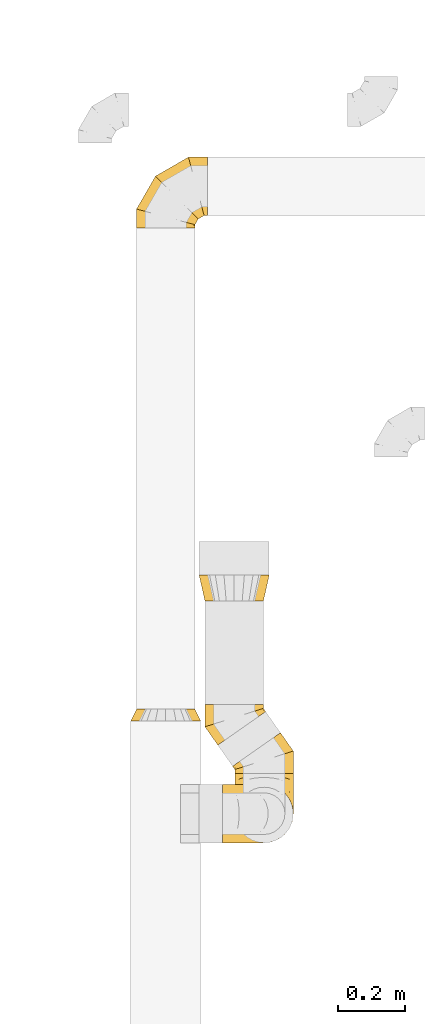
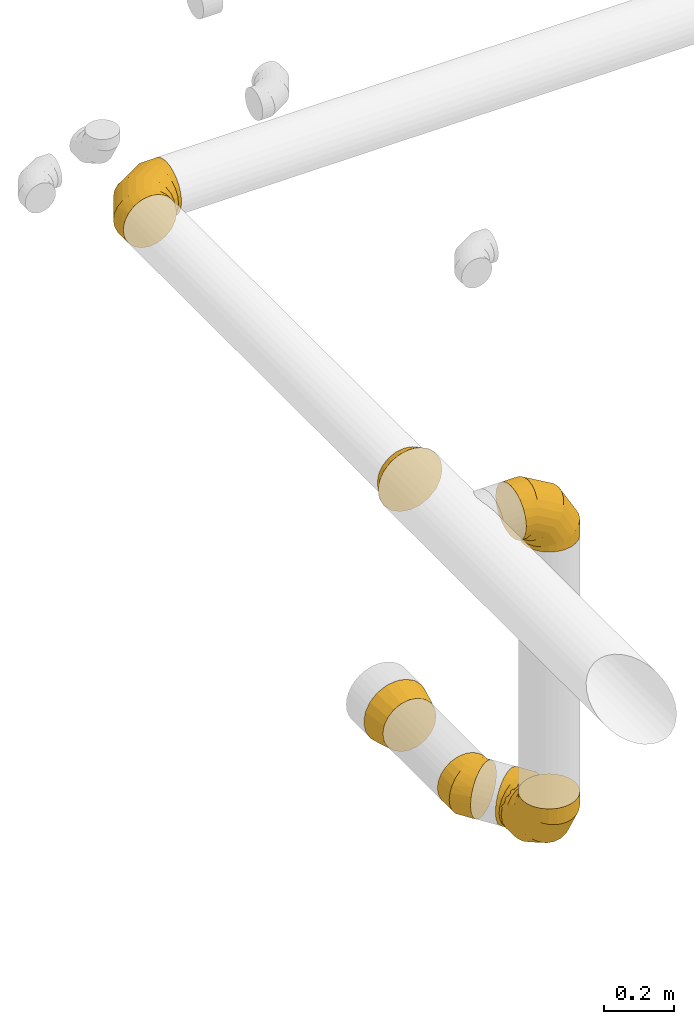
# One storey, part 27 of 97: 7 coverings.
"""IFC2X3 building model written with IfcOpenShell, lengths in millimetres."""

from ifc_helpers import new_model, entity, si_unit, converted_unit, derived_unit, direction, frame, origin, place, context, subcontext, project, spatial, faceted_brep, element, save


model = new_model("IFC2X3")

# Units and contexts
model_context = context("Model", 3, precision=0.01, world=origin(), true_north=direction((6.12303176911189e-17, 1.0)))
body_context = subcontext(model_context, "Body", "Model", "MODEL_VIEW")
ifc_project = project(units=[si_unit("LENGTHUNIT", "METRE", prefix="MILLI"), si_unit("AREAUNIT", "SQUARE_METRE"), si_unit("VOLUMEUNIT", "CUBIC_METRE"), converted_unit("PLANEANGLEUNIT", "DEGREE", entity("IfcRatioMeasure", 0.0174532925199433), si_unit("PLANEANGLEUNIT", "RADIAN"), dimensions=[0, 0, 0, 0, 0, 0, 0]), si_unit("MASSUNIT", "GRAM", prefix="KILO"), derived_unit("MASSDENSITYUNIT", [(si_unit("MASSUNIT", "GRAM", prefix="KILO"), 1), (si_unit("LENGTHUNIT", "METRE"), -3)]), derived_unit("MOMENTOFINERTIAUNIT", [(si_unit("LENGTHUNIT", "METRE"), 4)]), si_unit("TIMEUNIT", "SECOND"), si_unit("FREQUENCYUNIT", "HERTZ"), si_unit("THERMODYNAMICTEMPERATUREUNIT", "DEGREE_CELSIUS"), derived_unit("THERMALTRANSMITTANCEUNIT", [(si_unit("MASSUNIT", "GRAM", prefix="KILO"), 1), (si_unit("THERMODYNAMICTEMPERATUREUNIT", "KELVIN"), -1), (si_unit("TIMEUNIT", "SECOND"), -3)]), derived_unit("VOLUMETRICFLOWRATEUNIT", [(si_unit("LENGTHUNIT", "METRE"), 3), (si_unit("TIMEUNIT", "SECOND"), -1)]), derived_unit("MASSFLOWRATEUNIT", [(si_unit("MASSUNIT", "GRAM", prefix="KILO"), 1), (si_unit("TIMEUNIT", "SECOND"), -1)]), derived_unit("ROTATIONALFREQUENCYUNIT", [(si_unit("TIMEUNIT", "SECOND"), -1)]), si_unit("ELECTRICCURRENTUNIT", "AMPERE"), si_unit("ELECTRICVOLTAGEUNIT", "VOLT"), si_unit("POWERUNIT", "WATT"), si_unit("FORCEUNIT", "NEWTON", prefix="KILO"), si_unit("ILLUMINANCEUNIT", "LUX"), si_unit("LUMINOUSFLUXUNIT", "LUMEN"), si_unit("LUMINOUSINTENSITYUNIT", "CANDELA"), derived_unit("USERDEFINED", [(si_unit("MASSUNIT", "GRAM", prefix="KILO"), -1), (si_unit("LENGTHUNIT", "METRE"), -2), (si_unit("TIMEUNIT", "SECOND"), 3), (si_unit("LUMINOUSFLUXUNIT", "LUMEN"), 1)]), derived_unit("LINEARVELOCITYUNIT", [(si_unit("LENGTHUNIT", "METRE"), 1), (si_unit("TIMEUNIT", "SECOND"), -1)]), si_unit("PRESSUREUNIT", "PASCAL"), derived_unit("USERDEFINED", [(si_unit("LENGTHUNIT", "METRE"), -2), (si_unit("MASSUNIT", "GRAM", prefix="KILO"), 1), (si_unit("TIMEUNIT", "SECOND"), -2)]), derived_unit("LINEARFORCEUNIT", [(si_unit("MASSUNIT", "GRAM", prefix="KILO"), 1), (si_unit("LENGTHUNIT", "METRE"), 1), (si_unit("TIMEUNIT", "SECOND"), -2), (si_unit("LENGTHUNIT", "METRE"), -1)]), derived_unit("PLANARFORCEUNIT", [(si_unit("MASSUNIT", "GRAM", prefix="KILO"), 1), (si_unit("LENGTHUNIT", "METRE"), 1), (si_unit("TIMEUNIT", "SECOND"), -2), (si_unit("LENGTHUNIT", "METRE"), -2)])], contexts=[model_context])

# Site, building, storey
site_placement = place(None, origin())
site = spatial("IfcSite", under=ifc_project, at=site_placement, CompositionType="ELEMENT")
building_placement = place(site_placement, origin())
building = spatial("IfcBuilding", under=site, at=building_placement, CompositionType="ELEMENT")
storey_placement = place(building_placement, frame((0.0, 0.0, -4900.0)))
storey = spatial("IfcBuildingStorey", under=building, at=storey_placement, CompositionType="ELEMENT", Elevation=-4900.0)

# Coverings
covering_1_placement = place(storey_placement, frame((67387.61, 17132.04, 3893.4)))
element("IfcCovering", 1, at=covering_1_placement, inside=storey, PredefinedType="INSULATION", context=body_context, shape_type="Brep", body=[
    faceted_brep([(79.56, 35.0, 189.81), (106.6, 35.0, 194.1), (133.63, 35.0, 189.81), (158.03, 35.0, 177.38), (177.38, 35.0, 158.03), (189.81, 35.0, 133.63), (194.1, 35.0, 106.6), (189.81, 35.0, 79.56), (177.38, 35.0, 55.16), (158.03, 35.0, 35.81), (133.63, 35.0, 23.38), (106.6, 35.0, 19.1), (79.56, 35.0, 23.38), (55.16, 35.0, 35.81), (35.81, 35.0, 55.16), (23.38, 35.0, 79.56), (19.1, 35.0, 106.6), (23.38, 35.0, 133.63), (35.81, 35.0, 158.03), (55.16, 35.0, 177.38), (1.6, 0.0, 106.6), (6.73, 0.0, 74.15), (21.65, 0.0, 44.88), (44.88, 0.0, 21.65), (74.15, 0.0, 6.73), (106.6, 0.0, 1.6), (139.04, 0.0, 6.73), (168.31, 0.0, 21.65), (191.54, 0.0, 44.88), (206.46, 0.0, 74.15), (211.6, 0.0, 106.6), (206.46, 0.0, 139.04), (191.54, 0.0, 168.31), (168.31, 0.0, 191.54), (139.04, 0.0, 206.46), (106.6, 0.0, 211.6), (74.15, 0.0, 206.46), (44.88, 0.0, 191.54), (21.65, 0.0, 168.31), (6.73, 0.0, 139.04)], [[[0, 1, 2, 3, 4, 5, 6, 7, 8, 9, 10, 11, 12, 13, 14, 15, 16, 17, 18, 19]], [[20, 21, 22, 23, 24, 25, 26, 27, 28, 29, 30, 31, 32, 33, 34, 35, 36, 37, 38, 39]], [[26, 25, 11, 10]], [[26, 10, 9, 27]], [[9, 8, 28, 27]], [[7, 6, 30, 29]], [[8, 7, 29, 28]], [[21, 20, 16, 15]], [[21, 15, 14, 22]], [[14, 13, 23, 22]], [[12, 11, 25, 24]], [[13, 12, 24, 23]], [[36, 35, 1, 0]], [[36, 0, 19, 37]], [[19, 18, 38, 37]], [[17, 16, 20, 39]], [[18, 17, 39, 38]], [[31, 30, 6, 5]], [[31, 5, 4, 32]], [[4, 3, 33, 32]], [[2, 1, 35, 34]], [[3, 2, 34, 33]]]),
])
covering_2_placement = place(storey_placement, frame((67405.11, 18609.13, 3910.9)))
element("IfcCovering", 2, at=covering_2_placement, inside=storey, PredefinedType="INSULATION", context=body_context, shape_type="Brep", body=[
    faceted_brep([(116.13, 0.0, 172.31), (89.1, 0.0, 176.6), (62.06, 0.0, 172.31), (37.66, 0.0, 159.88), (18.31, 0.0, 140.53), (5.88, 0.0, 116.13), (1.6, 0.0, 89.1), (5.88, 0.0, 62.06), (18.31, 0.0, 37.66), (37.66, 0.0, 18.31), (62.06, 0.0, 5.88), (89.1, 0.0, 1.6), (116.13, 0.0, 5.88), (140.53, 0.0, 18.31), (159.88, 0.0, 37.66), (166.1, 0.0, 49.86), (172.31, 0.0, 62.06), (174.45, 0.0, 75.58), (176.6, 0.0, 89.1), (174.45, 0.0, 102.61), (172.31, 0.0, 116.13), (166.1, 0.0, 128.33), (159.88, 0.0, 140.53), (140.53, 0.0, 159.88), (214.1, 200.78, 45.35), (214.1, 209.52, 66.45), (214.1, 212.5, 89.1), (214.1, 209.52, 111.74), (214.1, 200.78, 132.85), (214.1, 186.87, 150.97), (214.1, 168.75, 164.87), (214.1, 147.65, 173.61), (214.1, 125.0, 176.6), (214.1, 102.35, 173.61), (214.1, 81.25, 164.87), (214.1, 63.13, 150.97), (214.1, 49.22, 132.85), (214.1, 40.48, 111.74), (214.1, 37.5, 89.1), (214.1, 40.48, 66.45), (214.1, 49.22, 45.35), (214.1, 63.13, 27.22), (214.1, 81.25, 13.32), (214.1, 102.35, 4.58), (214.1, 125.0, 1.6), (214.1, 147.65, 4.58), (214.1, 168.75, 13.32), (214.1, 186.87, 27.22), (157.16, 212.5, 89.1), (157.95, 209.52, 111.74), (160.3, 200.78, 132.85), (164.02, 186.87, 150.97), (168.88, 168.75, 164.87), (174.53, 147.65, 173.61), (180.6, 125.0, 176.6), (186.67, 102.35, 173.61), (192.32, 81.25, 164.87), (197.18, 63.13, 150.97), (200.91, 49.22, 132.85), (203.25, 40.48, 111.74), (204.05, 37.5, 89.1), (203.25, 40.48, 66.45), (200.91, 49.22, 45.35), (197.18, 63.13, 27.22), (186.67, 102.35, 4.58), (180.6, 125.0, 1.6), (192.32, 81.25, 13.32), (174.53, 147.65, 4.58), (168.88, 168.75, 13.32), (164.02, 186.87, 27.22), (160.3, 200.78, 45.35), (157.95, 209.52, 66.45), (58.53, 155.56, 89.1), (60.72, 153.38, 111.74), (67.12, 146.98, 132.85), (77.3, 136.8, 150.97), (90.56, 123.53, 164.87), (106.01, 108.08, 173.61), (122.59, 91.51, 176.6), (139.17, 74.93, 173.61), (154.62, 59.48, 164.87), (167.88, 46.21, 150.97), (178.06, 36.03, 132.85), (184.46, 29.63, 111.74), (186.64, 27.45, 89.1), (184.46, 29.63, 66.45), (178.06, 36.03, 45.35), (167.88, 46.21, 27.22), (139.17, 74.93, 4.58), (122.59, 91.51, 1.6), (154.62, 59.48, 13.32), (106.01, 108.08, 4.58), (90.56, 123.53, 13.32), (77.3, 136.8, 27.22), (67.12, 146.98, 45.35), (60.72, 153.38, 66.45), (1.6, 56.94, 89.1), (4.58, 56.14, 111.74), (13.32, 53.8, 132.85), (27.22, 50.07, 150.97), (45.35, 45.22, 164.87), (66.45, 39.56, 173.61), (89.1, 33.49, 176.6), (111.74, 27.43, 173.61), (132.85, 21.77, 164.87), (150.97, 16.92, 150.97), (164.87, 13.19, 132.85), (173.61, 10.85, 111.74), (175.1, 10.45, 100.42), (176.6, 10.05, 89.1), (173.61, 10.85, 66.45), (164.87, 13.19, 45.35), (175.1, 10.45, 77.77), (150.97, 16.92, 27.22), (111.74, 27.43, 4.58), (89.1, 33.49, 1.6), (132.85, 21.77, 13.32), (66.45, 39.56, 4.58), (45.35, 45.22, 13.32), (27.22, 50.07, 27.22), (13.32, 53.8, 45.35), (4.58, 56.14, 66.45)], [[[0, 1, 2, 3, 4, 5, 6, 7, 8, 9, 10, 11, 12, 13, 14, 15, 16, 17, 18, 19, 20, 21, 22, 23]], [[24, 25, 26, 27, 28, 29, 30, 31, 32, 33, 34, 35, 36, 37, 38, 39, 40, 41, 42, 43, 44, 45, 46, 47]], [[26, 48, 49, 27]], [[27, 49, 50, 28]], [[28, 50, 51, 29]], [[30, 52, 53, 31]], [[31, 53, 54, 32]], [[29, 51, 52, 30]], [[55, 56, 34, 33]], [[54, 55, 33, 32]], [[57, 35, 34, 56]], [[58, 59, 37, 36]], [[58, 36, 35, 57]], [[60, 38, 37, 59]], [[61, 62, 40, 39]], [[60, 61, 39, 38]], [[41, 40, 62, 63]], [[64, 65, 44, 43]], [[66, 64, 43, 42]], [[63, 66, 42, 41]], [[46, 45, 67, 68]], [[47, 46, 68, 69]], [[44, 65, 67, 45]], [[25, 24, 70, 71]], [[26, 25, 71, 48]], [[69, 70, 24, 47]], [[49, 48, 72, 73]], [[50, 49, 73, 74]], [[74, 75, 51, 50]], [[52, 51, 75, 76]], [[53, 52, 76, 77]], [[54, 53, 77, 78]], [[79, 80, 56, 55]], [[78, 79, 55, 54]], [[57, 56, 80, 81]], [[82, 83, 59, 58]], [[81, 82, 58, 57]], [[60, 59, 83, 84]], [[85, 86, 62, 61]], [[84, 85, 61, 60]], [[63, 62, 86, 87]], [[88, 89, 65, 64]], [[90, 88, 64, 66]], [[87, 90, 66, 63]], [[67, 65, 89, 91]], [[68, 67, 91, 92]], [[69, 68, 92, 93]], [[71, 70, 94, 95]], [[48, 71, 95, 72]], [[93, 94, 70, 69]], [[73, 72, 96, 97]], [[74, 73, 97, 98]], [[98, 99, 75, 74]], [[76, 75, 99, 100]], [[77, 76, 100, 101]], [[78, 77, 101, 102]], [[103, 104, 80, 79]], [[102, 103, 79, 78]], [[81, 80, 104, 105]], [[106, 107, 83, 82]], [[105, 106, 82, 81]], [[84, 83, 107, 108, 109]], [[110, 111, 86, 85]], [[85, 84, 109, 112, 110]], [[87, 86, 111, 113]], [[114, 115, 89, 88]], [[116, 114, 88, 90]], [[113, 116, 90, 87]], [[91, 89, 115, 117]], [[92, 91, 117, 118]], [[93, 92, 118, 119]], [[95, 94, 120, 121]], [[72, 95, 121, 96]], [[119, 120, 94, 93]], [[97, 6, 5]], [[98, 5, 4]], [[6, 97, 96]], [[97, 5, 98]], [[4, 99, 98]], [[100, 3, 2]], [[101, 2, 1]], [[99, 3, 100]], [[100, 2, 101]], [[1, 102, 101]], [[3, 99, 4]], [[103, 1, 0]], [[104, 0, 23]], [[103, 102, 1]], [[104, 103, 0]], [[23, 105, 104]], [[21, 20, 107]], [[18, 109, 108]], [[107, 20, 19]], [[106, 105, 22]], [[106, 22, 21]], [[107, 19, 108]], [[21, 107, 106]], [[18, 108, 19]], [[22, 105, 23]], [[110, 17, 16]], [[111, 15, 14]], [[18, 112, 109]], [[18, 17, 112]], [[110, 16, 15]], [[110, 15, 111]], [[14, 113, 111]], [[116, 13, 12]], [[114, 12, 11]], [[116, 113, 13]], [[115, 114, 11]], [[116, 12, 114]], [[17, 110, 112]], [[13, 113, 14]], [[117, 11, 10]], [[118, 10, 9]], [[11, 117, 115]], [[117, 10, 118]], [[9, 119, 118]], [[120, 8, 7]], [[121, 7, 6]], [[119, 8, 120]], [[121, 120, 7]], [[96, 121, 6]], [[8, 119, 9]]]),
])
covering_3_placement = place(storey_placement, frame((67699.89, 16764.8, 2770.9)))
element("IfcCovering", 3, at=covering_3_placement, inside=storey, PredefinedType="INSULATION", context=body_context, shape_type="Brep", body=[
    faceted_brep([(172.31, 214.1, 116.13), (176.6, 214.1, 89.1), (172.31, 214.1, 62.06), (159.88, 214.1, 37.66), (140.53, 214.1, 18.31), (116.13, 214.1, 5.88), (89.1, 214.1, 1.6), (62.06, 214.1, 5.88), (37.66, 214.1, 18.31), (18.31, 214.1, 37.66), (5.88, 214.1, 62.06), (1.6, 214.1, 89.1), (5.88, 214.1, 116.13), (18.31, 214.1, 140.53), (37.66, 214.1, 159.88), (49.86, 214.1, 166.1), (62.06, 214.1, 172.31), (75.58, 214.1, 174.45), (89.1, 214.1, 176.6), (102.61, 214.1, 174.45), (116.13, 214.1, 172.31), (128.33, 214.1, 166.1), (140.53, 214.1, 159.88), (159.88, 214.1, 140.53), (45.35, 13.32, 214.1), (66.45, 4.58, 214.1), (89.1, 1.6, 214.1), (111.74, 4.58, 214.1), (132.85, 13.32, 214.1), (150.97, 27.22, 214.1), (164.87, 45.35, 214.1), (173.61, 66.45, 214.1), (176.6, 89.1, 214.1), (173.61, 111.74, 214.1), (164.87, 132.85, 214.1), (150.97, 150.97, 214.1), (132.85, 164.87, 214.1), (111.74, 173.61, 214.1), (89.1, 176.6, 214.1), (66.45, 173.61, 214.1), (45.35, 164.87, 214.1), (27.22, 150.97, 214.1), (13.32, 132.85, 214.1), (4.58, 111.74, 214.1), (1.6, 89.1, 214.1), (4.58, 66.45, 214.1), (13.32, 45.35, 214.1), (27.22, 27.22, 214.1), (89.1, 1.6, 157.16), (111.74, 4.58, 157.95), (132.85, 13.32, 160.3), (150.97, 27.22, 164.02), (164.87, 45.35, 168.88), (173.61, 66.45, 174.53), (176.6, 89.1, 180.6), (173.61, 111.74, 186.67), (164.87, 132.85, 192.32), (150.97, 150.97, 197.18), (132.85, 164.87, 200.91), (111.74, 173.61, 203.25), (89.1, 176.6, 204.05), (66.45, 173.61, 203.25), (45.35, 164.87, 200.91), (27.22, 150.97, 197.18), (4.58, 111.74, 186.67), (1.6, 89.1, 180.6), (13.32, 132.85, 192.32), (4.58, 66.45, 174.53), (13.32, 45.35, 168.88), (27.22, 27.22, 164.02), (45.35, 13.32, 160.3), (66.45, 4.58, 157.95), (89.1, 58.53, 58.53), (111.74, 60.72, 60.72), (132.85, 67.12, 67.12), (150.97, 77.3, 77.3), (164.87, 90.56, 90.56), (173.61, 106.01, 106.01), (176.6, 122.59, 122.59), (173.61, 139.17, 139.17), (164.87, 154.62, 154.62), (150.97, 167.88, 167.88), (132.85, 178.06, 178.06), (111.74, 184.46, 184.46), (89.1, 186.64, 186.64), (66.45, 184.46, 184.46), (45.35, 178.06, 178.06), (27.22, 167.88, 167.88), (4.58, 139.17, 139.17), (1.6, 122.59, 122.59), (13.32, 154.62, 154.62), (4.58, 106.01, 106.01), (13.32, 90.56, 90.56), (27.22, 77.3, 77.3), (45.35, 67.12, 67.12), (66.45, 60.72, 60.72), (89.1, 157.16, 1.6), (111.74, 157.95, 4.58), (132.85, 160.3, 13.32), (150.97, 164.02, 27.22), (164.87, 168.88, 45.35), (173.61, 174.53, 66.45), (176.6, 180.6, 89.1), (173.61, 186.67, 111.74), (164.87, 192.32, 132.85), (150.97, 197.18, 150.97), (132.85, 200.91, 164.87), (111.74, 203.25, 173.61), (100.42, 203.65, 175.1), (89.1, 204.05, 176.6), (66.45, 203.25, 173.61), (45.35, 200.91, 164.87), (77.77, 203.65, 175.1), (27.22, 197.18, 150.97), (4.58, 186.67, 111.74), (1.6, 180.6, 89.1), (13.32, 192.32, 132.85), (4.58, 174.53, 66.45), (13.32, 168.88, 45.35), (27.22, 164.02, 27.22), (45.35, 160.3, 13.32), (66.45, 157.95, 4.58)], [[[0, 1, 2, 3, 4, 5, 6, 7, 8, 9, 10, 11, 12, 13, 14, 15, 16, 17, 18, 19, 20, 21, 22, 23]], [[24, 25, 26, 27, 28, 29, 30, 31, 32, 33, 34, 35, 36, 37, 38, 39, 40, 41, 42, 43, 44, 45, 46, 47]], [[26, 48, 49, 27]], [[27, 49, 50, 28]], [[28, 50, 51, 29]], [[30, 52, 53, 31]], [[31, 53, 54, 32]], [[29, 51, 52, 30]], [[55, 56, 34, 33]], [[54, 55, 33, 32]], [[57, 35, 34, 56]], [[58, 59, 37, 36]], [[58, 36, 35, 57]], [[60, 38, 37, 59]], [[61, 62, 40, 39]], [[60, 61, 39, 38]], [[41, 40, 62, 63]], [[64, 65, 44, 43]], [[66, 64, 43, 42]], [[63, 66, 42, 41]], [[46, 45, 67, 68]], [[47, 46, 68, 69]], [[44, 65, 67, 45]], [[25, 24, 70, 71]], [[26, 25, 71, 48]], [[69, 70, 24, 47]], [[49, 48, 72, 73]], [[50, 49, 73, 74]], [[74, 75, 51, 50]], [[52, 51, 75, 76]], [[53, 52, 76, 77]], [[54, 53, 77, 78]], [[79, 80, 56, 55]], [[78, 79, 55, 54]], [[57, 56, 80, 81]], [[82, 83, 59, 58]], [[81, 82, 58, 57]], [[60, 59, 83, 84]], [[85, 86, 62, 61]], [[84, 85, 61, 60]], [[63, 62, 86, 87]], [[88, 89, 65, 64]], [[90, 88, 64, 66]], [[87, 90, 66, 63]], [[67, 65, 89, 91]], [[68, 67, 91, 92]], [[69, 68, 92, 93]], [[71, 70, 94, 95]], [[48, 71, 95, 72]], [[93, 94, 70, 69]], [[73, 72, 96, 97]], [[74, 73, 97, 98]], [[98, 99, 75, 74]], [[76, 75, 99, 100]], [[77, 76, 100, 101]], [[78, 77, 101, 102]], [[103, 104, 80, 79]], [[102, 103, 79, 78]], [[81, 80, 104, 105]], [[106, 107, 83, 82]], [[105, 106, 82, 81]], [[84, 83, 107, 108, 109]], [[110, 111, 86, 85]], [[85, 84, 109, 112, 110]], [[87, 86, 111, 113]], [[114, 115, 89, 88]], [[116, 114, 88, 90]], [[113, 116, 90, 87]], [[91, 89, 115, 117]], [[92, 91, 117, 118]], [[93, 92, 118, 119]], [[95, 94, 120, 121]], [[72, 95, 121, 96]], [[119, 120, 94, 93]], [[97, 6, 5]], [[98, 5, 4]], [[6, 97, 96]], [[97, 5, 98]], [[4, 99, 98]], [[100, 3, 2]], [[101, 2, 1]], [[99, 3, 100]], [[100, 2, 101]], [[1, 102, 101]], [[3, 99, 4]], [[103, 1, 0]], [[104, 0, 23]], [[103, 102, 1]], [[104, 103, 0]], [[23, 105, 104]], [[21, 20, 107]], [[18, 109, 108]], [[107, 20, 19]], [[106, 105, 22]], [[106, 22, 21]], [[107, 19, 108]], [[21, 107, 106]], [[18, 108, 19]], [[22, 105, 23]], [[110, 17, 16]], [[111, 15, 14]], [[18, 112, 109]], [[18, 17, 112]], [[110, 16, 15]], [[110, 15, 111]], [[14, 113, 111]], [[116, 13, 12]], [[114, 12, 11]], [[116, 113, 13]], [[115, 114, 11]], [[116, 12, 114]], [[17, 110, 112]], [[13, 113, 14]], [[117, 11, 10]], [[118, 10, 9]], [[11, 117, 115]], [[117, 10, 118]], [[9, 119, 118]], [[120, 8, 7]], [[121, 7, 6]], [[119, 8, 120]], [[121, 120, 7]], [[96, 121, 6]], [[8, 119, 9]]]),
])
covering_4_placement = place(storey_placement, frame((67693.11, 16974.48, 2770.9)))
element("IfcCovering", 4, at=covering_4_placement, inside=storey, PredefinedType="INSULATION", context=body_context, shape_type="Brep", body=[
    faceted_brep([(5.1, 23.97, 116.13), (10.19, 27.53, 128.33), (15.28, 31.09, 140.53), (31.14, 42.2, 159.88), (51.12, 56.19, 172.31), (73.27, 71.7, 176.6), (95.42, 87.21, 172.31), (115.4, 101.2, 159.88), (131.26, 112.3, 140.53), (141.44, 119.43, 116.13), (144.95, 121.88, 89.1), (141.44, 119.43, 62.06), (131.26, 112.3, 37.66), (115.4, 101.2, 18.31), (95.42, 87.21, 5.88), (73.27, 71.7, 1.6), (51.12, 56.19, 5.88), (31.14, 42.2, 18.31), (15.28, 31.09, 37.66), (10.19, 27.53, 49.86), (5.1, 23.97, 62.06), (3.35, 22.74, 75.58), (1.6, 21.51, 89.1), (3.35, 22.74, 102.61), (171.65, 0.0, 45.35), (180.4, 0.0, 66.45), (183.38, 0.0, 89.1), (180.4, 0.0, 111.74), (171.65, 0.0, 132.85), (157.75, 0.0, 150.97), (139.63, 0.0, 164.87), (118.52, 0.0, 173.61), (95.88, 0.0, 176.6), (73.23, 0.0, 173.61), (52.13, 0.0, 164.87), (34.01, 0.0, 150.97), (20.1, 0.0, 132.85), (11.36, 0.0, 111.74), (8.38, 0.0, 89.1), (11.36, 0.0, 66.45), (20.1, 0.0, 45.35), (34.01, 0.0, 27.22), (52.13, 0.0, 13.32), (73.23, 0.0, 4.58), (95.88, 0.0, 1.6), (118.52, 0.0, 4.58), (139.63, 0.0, 13.32), (157.75, 0.0, 27.22), (183.38, 67.0, 89.1), (180.4, 66.06, 111.74), (171.65, 63.3, 132.85), (157.75, 58.92, 150.97), (139.63, 53.21, 164.87), (118.52, 46.55, 173.61), (95.88, 39.41, 176.6), (73.23, 32.27, 173.61), (52.13, 25.62, 164.87), (34.01, 19.9, 150.97), (20.1, 15.52, 132.85), (11.36, 12.76, 111.74), (8.38, 11.82, 89.1), (9.87, 12.29, 100.42), (11.36, 12.76, 66.45), (20.1, 15.52, 45.35), (9.87, 12.29, 77.77), (34.01, 19.9, 27.22), (73.23, 32.27, 4.58), (95.88, 39.41, 1.6), (52.13, 25.62, 13.32), (118.52, 46.55, 4.58), (139.63, 53.21, 13.32), (157.75, 58.92, 27.22), (171.65, 63.3, 45.35), (180.4, 66.06, 66.45)], [[[0, 1, 2, 3, 4, 5, 6, 7, 8, 9, 10, 11, 12, 13, 14, 15, 16, 17, 18, 19, 20, 21, 22, 23]], [[24, 25, 26, 27, 28, 29, 30, 31, 32, 33, 34, 35, 36, 37, 38, 39, 40, 41, 42, 43, 44, 45, 46, 47]], [[26, 48, 49, 27]], [[27, 49, 50, 28]], [[51, 29, 28, 50]], [[29, 51, 52, 30]], [[30, 52, 53, 31]], [[54, 32, 31, 53]], [[55, 56, 34, 33]], [[54, 55, 33, 32]], [[57, 35, 34, 56]], [[58, 59, 37, 36]], [[58, 36, 35, 57]], [[60, 38, 37, 59, 61]], [[62, 63, 40, 39]], [[39, 38, 60, 64, 62]], [[41, 40, 63, 65]], [[66, 67, 44, 43]], [[68, 66, 43, 42]], [[65, 68, 42, 41]], [[45, 44, 67, 69]], [[46, 45, 69, 70]], [[70, 71, 47, 46]], [[25, 24, 72, 73]], [[26, 25, 73, 48]], [[71, 72, 24, 47]], [[49, 10, 9]], [[50, 9, 8]], [[10, 49, 48]], [[49, 9, 50]], [[8, 51, 50]], [[52, 7, 6]], [[53, 6, 5]], [[51, 7, 52]], [[52, 6, 53]], [[5, 54, 53]], [[7, 51, 8]], [[55, 5, 4]], [[56, 4, 3]], [[55, 54, 5]], [[56, 55, 4]], [[3, 57, 56]], [[1, 0, 59]], [[22, 60, 61]], [[59, 0, 23]], [[58, 57, 2]], [[58, 2, 1]], [[59, 23, 61]], [[1, 59, 58]], [[22, 61, 23]], [[2, 57, 3]], [[62, 21, 20]], [[63, 19, 18]], [[22, 64, 60]], [[22, 21, 64]], [[62, 20, 19]], [[62, 19, 63]], [[18, 65, 63]], [[68, 17, 16]], [[66, 16, 15]], [[68, 65, 17]], [[67, 66, 15]], [[68, 16, 66]], [[21, 62, 64]], [[17, 65, 18]], [[69, 15, 14]], [[70, 14, 13]], [[15, 69, 67]], [[69, 14, 70]], [[13, 71, 70]], [[72, 12, 11]], [[73, 11, 10]], [[71, 12, 72]], [[73, 72, 11]], [[48, 73, 10]], [[12, 71, 13]]]),
])
covering_5_placement = place(storey_placement, frame((67610.22, 17057.88, 2770.9)))
element("IfcCovering", 5, at=covering_5_placement, inside=storey, PredefinedType="INSULATION", context=body_context, shape_type="Brep", body=[
    faceted_brep([(179.87, 99.51, 116.13), (174.78, 95.95, 128.33), (169.69, 92.39, 140.53), (153.83, 81.28, 159.88), (133.85, 67.29, 172.31), (111.7, 51.78, 176.6), (89.55, 36.27, 172.31), (69.57, 22.28, 159.88), (53.71, 11.18, 140.53), (43.53, 4.05, 116.13), (40.03, 1.6, 89.1), (43.53, 4.05, 62.06), (53.71, 11.18, 37.66), (69.57, 22.28, 18.31), (89.55, 36.27, 5.88), (111.7, 51.78, 1.6), (133.85, 67.29, 5.88), (153.83, 81.28, 18.31), (169.69, 92.39, 37.66), (174.78, 95.95, 49.86), (179.87, 99.51, 62.06), (181.62, 100.74, 75.58), (183.38, 101.97, 89.1), (181.62, 100.74, 102.61), (13.32, 123.48, 45.35), (4.58, 123.48, 66.45), (1.6, 123.48, 89.1), (4.58, 123.48, 111.74), (13.32, 123.48, 132.85), (27.22, 123.48, 150.97), (45.35, 123.48, 164.87), (66.45, 123.48, 173.61), (89.1, 123.48, 176.6), (111.74, 123.48, 173.61), (132.85, 123.48, 164.87), (150.97, 123.48, 150.97), (164.87, 123.48, 132.85), (173.61, 123.48, 111.74), (176.6, 123.48, 89.1), (173.61, 123.48, 66.45), (164.87, 123.48, 45.35), (150.97, 123.48, 27.22), (132.85, 123.48, 13.32), (111.74, 123.48, 4.58), (89.1, 123.48, 1.6), (66.45, 123.48, 4.58), (45.35, 123.48, 13.32), (27.22, 123.48, 27.22), (1.6, 56.48, 89.1), (4.58, 57.42, 111.74), (13.32, 60.18, 132.85), (27.22, 64.56, 150.97), (45.35, 70.27, 164.87), (66.45, 76.93, 173.61), (89.1, 84.07, 176.6), (111.74, 91.21, 173.61), (132.85, 97.86, 164.87), (150.97, 103.58, 150.97), (164.87, 107.96, 132.85), (173.61, 110.72, 111.74), (176.6, 111.66, 89.1), (175.1, 111.19, 100.42), (173.61, 110.72, 66.45), (164.87, 107.96, 45.35), (175.1, 111.19, 77.77), (150.97, 103.58, 27.22), (111.74, 91.21, 4.58), (89.1, 84.07, 1.6), (132.85, 97.86, 13.32), (66.45, 76.93, 4.58), (45.35, 70.27, 13.32), (27.22, 64.56, 27.22), (13.32, 60.18, 45.35), (4.58, 57.42, 66.45)], [[[0, 1, 2, 3, 4, 5, 6, 7, 8, 9, 10, 11, 12, 13, 14, 15, 16, 17, 18, 19, 20, 21, 22, 23]], [[24, 25, 26, 27, 28, 29, 30, 31, 32, 33, 34, 35, 36, 37, 38, 39, 40, 41, 42, 43, 44, 45, 46, 47]], [[26, 48, 49, 27]], [[27, 49, 50, 28]], [[51, 29, 28, 50]], [[29, 51, 52, 30]], [[30, 52, 53, 31]], [[54, 32, 31, 53]], [[55, 56, 34, 33]], [[54, 55, 33, 32]], [[57, 35, 34, 56]], [[58, 59, 37, 36]], [[58, 36, 35, 57]], [[60, 38, 37, 59, 61]], [[62, 63, 40, 39]], [[39, 38, 60, 64, 62]], [[41, 40, 63, 65]], [[66, 67, 44, 43]], [[68, 66, 43, 42]], [[65, 68, 42, 41]], [[45, 44, 67, 69]], [[46, 45, 69, 70]], [[70, 71, 47, 46]], [[25, 24, 72, 73]], [[26, 25, 73, 48]], [[71, 72, 24, 47]], [[49, 10, 9]], [[50, 9, 8]], [[10, 49, 48]], [[49, 9, 50]], [[8, 51, 50]], [[52, 7, 6]], [[53, 6, 5]], [[51, 7, 52]], [[52, 6, 53]], [[5, 54, 53]], [[7, 51, 8]], [[55, 5, 4]], [[56, 4, 3]], [[55, 54, 5]], [[56, 55, 4]], [[3, 57, 56]], [[1, 0, 59]], [[22, 60, 61]], [[59, 0, 23]], [[58, 57, 2]], [[58, 2, 1]], [[59, 23, 61]], [[1, 59, 58]], [[22, 61, 23]], [[2, 57, 3]], [[62, 21, 20]], [[63, 19, 18]], [[22, 64, 60]], [[22, 21, 64]], [[62, 20, 19]], [[62, 19, 63]], [[18, 65, 63]], [[68, 17, 16]], [[66, 16, 15]], [[68, 65, 17]], [[67, 66, 15]], [[68, 16, 66]], [[21, 62, 64]], [[17, 65, 18]], [[69, 15, 14]], [[70, 14, 13]], [[15, 69, 67]], [[69, 14, 70]], [[13, 71, 70]], [[72, 12, 11]], [[73, 11, 10]], [[71, 12, 72]], [[73, 72, 11]], [[48, 73, 10]], [[12, 71, 13]]]),
])
covering_6_placement = place(storey_placement, frame((67592.72, 17490.91, 2753.4)))
element("IfcCovering", 6, at=covering_6_placement, inside=storey, PredefinedType="INSULATION", context=body_context, shape_type="Brep", body=[
    faceted_brep([(139.04, 78.0, 206.46), (168.31, 78.0, 191.54), (191.54, 78.0, 168.31), (206.46, 78.0, 139.04), (211.6, 78.0, 106.6), (206.46, 78.0, 74.15), (191.54, 78.0, 44.88), (168.31, 78.0, 21.65), (139.04, 78.0, 6.73), (106.6, 78.0, 1.6), (74.15, 78.0, 6.73), (44.88, 78.0, 21.65), (21.65, 78.0, 44.88), (6.73, 78.0, 74.15), (1.6, 78.0, 106.6), (6.73, 78.0, 139.04), (21.65, 78.0, 168.31), (44.88, 78.0, 191.54), (74.15, 78.0, 206.46), (106.6, 78.0, 211.6), (133.63, 0.0, 189.81), (106.6, 0.0, 194.1), (79.56, 0.0, 189.81), (55.16, 0.0, 177.38), (35.81, 0.0, 158.03), (23.38, 0.0, 133.63), (19.1, 0.0, 106.6), (23.38, 0.0, 79.56), (35.81, 0.0, 55.16), (55.16, 0.0, 35.81), (79.56, 0.0, 23.38), (106.6, 0.0, 19.1), (133.63, 0.0, 23.38), (158.03, 0.0, 35.81), (177.38, 0.0, 55.16), (189.81, 0.0, 79.56), (194.1, 0.0, 106.6), (189.81, 0.0, 133.63), (177.38, 0.0, 158.03), (158.03, 0.0, 177.38)], [[[0, 1, 2, 3, 4, 5, 6, 7, 8, 9, 10, 11, 12, 13, 14, 15, 16, 17, 18, 19]], [[20, 21, 22, 23, 24, 25, 26, 27, 28, 29, 30, 31, 32, 33, 34, 35, 36, 37, 38, 39]], [[5, 4, 36, 35]], [[6, 5, 35, 34]], [[34, 33, 7, 6]], [[32, 31, 9, 8]], [[33, 32, 8, 7]], [[10, 9, 31, 30]], [[11, 10, 30, 29]], [[29, 28, 12, 11]], [[27, 26, 14, 13]], [[28, 27, 13, 12]], [[15, 14, 26, 25]], [[16, 15, 25, 24]], [[24, 23, 17, 16]], [[22, 21, 19, 18]], [[23, 22, 18, 17]], [[0, 19, 21, 20]], [[1, 0, 20, 39]], [[39, 38, 2, 1]], [[37, 36, 4, 3]], [[38, 37, 3, 2]]]),
])
covering_7_placement = place(storey_placement, frame((67663.98, 16764.8, 3875.0)))
element("IfcCovering", 7, at=covering_7_placement, inside=storey, PredefinedType="INSULATION", context=body_context, shape_type="Brep", body=[
    faceted_brep([(0.0, 5.88, 97.96), (0.0, 1.6, 125.0), (0.0, 5.88, 152.04), (0.0, 18.31, 176.43), (0.0, 37.66, 195.79), (0.0, 62.06, 208.22), (0.0, 89.1, 212.5), (0.0, 116.13, 208.22), (0.0, 140.53, 195.79), (0.0, 159.88, 176.43), (0.0, 172.31, 152.04), (0.0, 176.6, 125.0), (0.0, 172.31, 97.96), (0.0, 159.88, 73.57), (0.0, 140.53, 54.21), (0.0, 128.33, 48.0), (0.0, 116.13, 41.78), (0.0, 102.61, 39.64), (0.0, 89.1, 37.5), (0.0, 75.58, 39.64), (0.0, 62.06, 41.78), (0.0, 49.86, 48.0), (0.0, 37.66, 54.21), (0.0, 18.31, 73.57), (200.78, 132.85, 0.0), (209.52, 111.74, 0.0), (212.5, 89.1, 0.0), (209.52, 66.45, 0.0), (200.78, 45.35, 0.0), (186.87, 27.22, 0.0), (168.75, 13.32, 0.0), (147.65, 4.58, 0.0), (125.0, 1.6, 0.0), (102.35, 4.58, 0.0), (81.25, 13.32, 0.0), (63.13, 27.22, 0.0), (49.22, 45.35, 0.0), (40.48, 66.45, 0.0), (37.5, 89.1, 0.0), (40.48, 111.74, 0.0), (49.22, 132.85, 0.0), (63.13, 150.97, 0.0), (81.25, 164.87, 0.0), (102.35, 173.61, 0.0), (125.0, 176.6, 0.0), (147.65, 173.61, 0.0), (168.75, 164.87, 0.0), (186.87, 150.97, 0.0), (212.5, 89.1, 56.94), (209.52, 66.45, 56.14), (200.78, 45.35, 53.8), (186.87, 27.22, 50.07), (168.75, 13.32, 45.22), (147.65, 4.58, 39.56), (125.0, 1.6, 33.49), (102.35, 4.58, 27.43), (81.25, 13.32, 21.77), (63.13, 27.22, 16.92), (49.22, 45.35, 13.19), (40.48, 66.45, 10.85), (37.5, 89.1, 10.05), (40.48, 111.74, 10.85), (49.22, 132.85, 13.19), (63.13, 150.97, 16.92), (102.35, 173.61, 27.43), (125.0, 176.6, 33.49), (81.25, 164.87, 21.77), (147.65, 173.61, 39.56), (168.75, 164.87, 45.22), (186.87, 150.97, 50.07), (200.78, 132.85, 53.8), (209.52, 111.74, 56.14), (155.56, 89.1, 155.56), (153.38, 66.45, 153.38), (146.98, 45.35, 146.98), (136.8, 27.22, 136.8), (123.53, 13.32, 123.53), (108.08, 4.58, 108.08), (91.51, 1.6, 91.51), (74.93, 4.58, 74.93), (59.48, 13.32, 59.48), (46.21, 27.22, 46.21), (36.03, 45.35, 36.03), (29.63, 66.45, 29.63), (27.45, 89.1, 27.45), (29.63, 111.74, 29.63), (36.03, 132.85, 36.03), (46.21, 150.97, 46.21), (74.93, 173.61, 74.93), (91.51, 176.6, 91.51), (59.48, 164.87, 59.48), (108.08, 173.61, 108.08), (123.53, 164.87, 123.53), (136.8, 150.97, 136.8), (146.98, 132.85, 146.98), (153.38, 111.74, 153.38), (56.94, 89.1, 212.5), (56.14, 66.45, 209.52), (53.8, 45.35, 200.78), (50.07, 27.22, 186.87), (45.22, 13.32, 168.75), (39.56, 4.58, 147.65), (33.49, 1.6, 125.0), (27.43, 4.58, 102.35), (21.77, 13.32, 81.25), (16.92, 27.22, 63.13), (13.19, 45.35, 49.22), (10.85, 66.45, 40.48), (10.45, 77.77, 38.99), (10.05, 89.1, 37.5), (10.85, 111.74, 40.48), (13.19, 132.85, 49.22), (10.45, 100.42, 38.99), (16.92, 150.97, 63.13), (27.43, 173.61, 102.35), (33.49, 176.6, 125.0), (21.77, 164.87, 81.25), (39.56, 173.61, 147.65), (45.22, 164.87, 168.75), (50.07, 150.97, 186.87), (53.8, 132.85, 200.78), (56.14, 111.74, 209.52)], [[[0, 1, 2, 3, 4, 5, 6, 7, 8, 9, 10, 11, 12, 13, 14, 15, 16, 17, 18, 19, 20, 21, 22, 23]], [[24, 25, 26, 27, 28, 29, 30, 31, 32, 33, 34, 35, 36, 37, 38, 39, 40, 41, 42, 43, 44, 45, 46, 47]], [[26, 48, 49, 27]], [[27, 49, 50, 28]], [[28, 50, 51, 29]], [[30, 52, 53, 31]], [[31, 53, 54, 32]], [[29, 51, 52, 30]], [[55, 56, 34, 33]], [[54, 55, 33, 32]], [[57, 35, 34, 56]], [[58, 59, 37, 36]], [[58, 36, 35, 57]], [[60, 38, 37, 59]], [[61, 62, 40, 39]], [[60, 61, 39, 38]], [[41, 40, 62, 63]], [[64, 65, 44, 43]], [[66, 64, 43, 42]], [[63, 66, 42, 41]], [[46, 45, 67, 68]], [[47, 46, 68, 69]], [[44, 65, 67, 45]], [[25, 24, 70, 71]], [[26, 25, 71, 48]], [[69, 70, 24, 47]], [[49, 48, 72, 73]], [[50, 49, 73, 74]], [[74, 75, 51, 50]], [[52, 51, 75, 76]], [[53, 52, 76, 77]], [[54, 53, 77, 78]], [[79, 80, 56, 55]], [[78, 79, 55, 54]], [[57, 56, 80, 81]], [[82, 83, 59, 58]], [[81, 82, 58, 57]], [[60, 59, 83, 84]], [[85, 86, 62, 61]], [[84, 85, 61, 60]], [[63, 62, 86, 87]], [[88, 89, 65, 64]], [[90, 88, 64, 66]], [[87, 90, 66, 63]], [[67, 65, 89, 91]], [[68, 67, 91, 92]], [[69, 68, 92, 93]], [[71, 70, 94, 95]], [[48, 71, 95, 72]], [[93, 94, 70, 69]], [[73, 72, 96, 97]], [[74, 73, 97, 98]], [[98, 99, 75, 74]], [[76, 75, 99, 100]], [[77, 76, 100, 101]], [[78, 77, 101, 102]], [[103, 104, 80, 79]], [[102, 103, 79, 78]], [[81, 80, 104, 105]], [[106, 107, 83, 82]], [[105, 106, 82, 81]], [[84, 83, 107, 108, 109]], [[110, 111, 86, 85]], [[85, 84, 109, 112, 110]], [[87, 86, 111, 113]], [[114, 115, 89, 88]], [[116, 114, 88, 90]], [[113, 116, 90, 87]], [[91, 89, 115, 117]], [[92, 91, 117, 118]], [[93, 92, 118, 119]], [[95, 94, 120, 121]], [[72, 95, 121, 96]], [[119, 120, 94, 93]], [[97, 6, 5]], [[98, 5, 4]], [[6, 97, 96]], [[97, 5, 98]], [[4, 99, 98]], [[100, 3, 2]], [[101, 2, 1]], [[99, 3, 100]], [[100, 2, 101]], [[1, 102, 101]], [[3, 99, 4]], [[103, 1, 0]], [[104, 0, 23]], [[103, 102, 1]], [[104, 103, 0]], [[23, 105, 104]], [[21, 20, 107]], [[18, 109, 108]], [[107, 20, 19]], [[106, 105, 22]], [[106, 22, 21]], [[107, 19, 108]], [[21, 107, 106]], [[18, 108, 19]], [[22, 105, 23]], [[110, 17, 16]], [[111, 15, 14]], [[18, 112, 109]], [[18, 17, 112]], [[110, 16, 15]], [[110, 15, 111]], [[14, 113, 111]], [[116, 13, 12]], [[114, 12, 11]], [[116, 113, 13]], [[115, 114, 11]], [[116, 12, 114]], [[17, 110, 112]], [[13, 113, 14]], [[117, 11, 10]], [[118, 10, 9]], [[11, 117, 115]], [[117, 10, 118]], [[9, 119, 118]], [[120, 8, 7]], [[121, 7, 6]], [[119, 8, 120]], [[121, 120, 7]], [[96, 121, 6]], [[8, 119, 9]]]),
])

save(model, "model.ifc")
